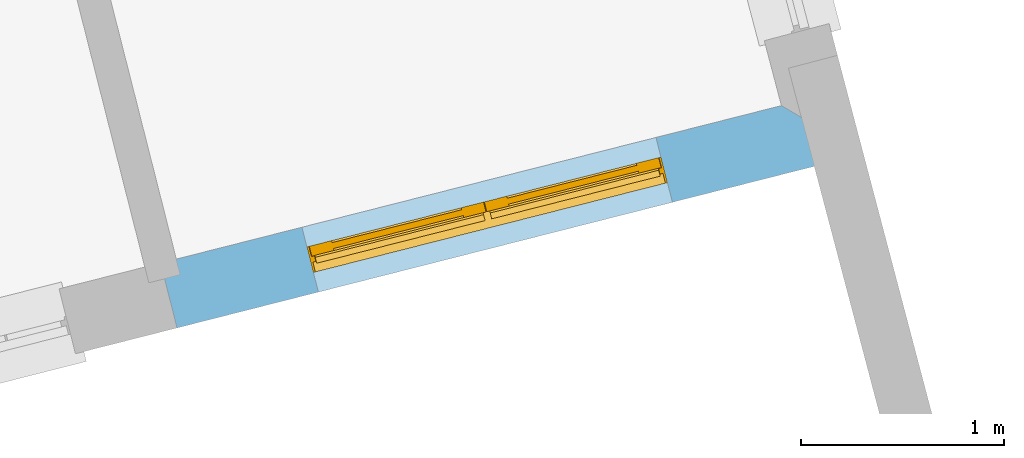
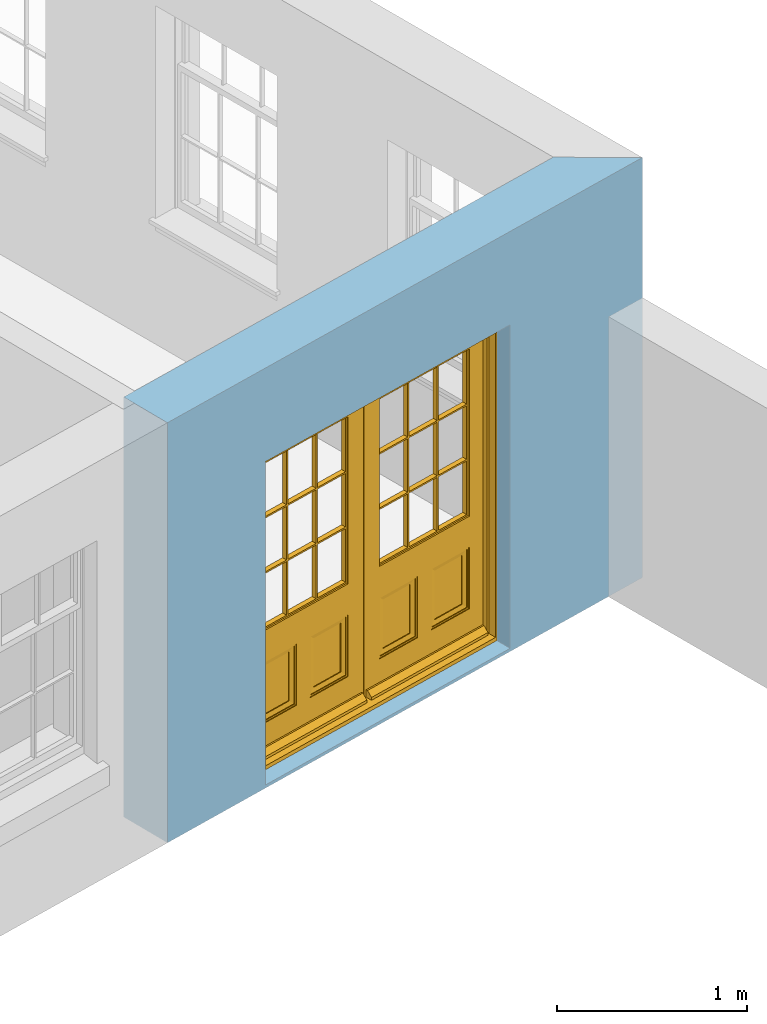
# One storey, part 9 of 15: 1 door, 1 opening, plus 1 element that does not belong to this part.
"""IFC2X3 building model written with IfcOpenShell, lengths in metres."""

from ifc_helpers import new_model, si_unit, frame, origin, place, context, subcontext, project, spatial, polyline, outline, extrude, faceted_brep, material, layer, layer_set, layer_usage, element, fill, save


model = new_model("IFC2X3")

# Units and contexts
model_context = context("Model", 3, world=origin())
body_context = subcontext(model_context, "Body", "Model", "MODEL_VIEW")
ifc_project = project(units=[si_unit("PLANEANGLEUNIT", "RADIAN"), si_unit("MASSUNIT", "GRAM", prefix="KILO"), si_unit("FORCEUNIT", "NEWTON", prefix="KILO"), si_unit("LENGTHUNIT", "METRE")], contexts=[model_context])

# Site, building, storey
site_placement = place(None, origin())
site = spatial("IfcSite", under=ifc_project, at=site_placement, CompositionType="ELEMENT")
building_placement = place(None, origin())
building = spatial("IfcBuilding", under=site, at=building_placement, Name="Building plot-13", CompositionType="ELEMENT")
storey_placement = place(None, frame((0.0, 0.0, 4.0)))
storey = spatial("IfcBuildingStorey", under=building, at=storey_placement, Name="Floor 0", CompositionType="ELEMENT", Elevation=4.0)

# Wall, opening, door
ifc_material = material(Name="Masonry")
ifc_layer = layer(ifc_material, 0.33, ventilated=False)
ifc_layer_set = layer_set([ifc_layer], Name="My Wall")
ifc_layer_usage = layer_usage(ifc_layer_set, "AXIS2", "NEGATIVE", 0.08)
wall_placement = place(storey_placement, origin())
wall = element("IfcWallStandardCase", 1, at=wall_placement, inside=storey, material=ifc_layer_usage, Name="exterior", context=body_context, shape_type="SweptSolid", body=[
    extrude(outline(polyline([(76.9221166060511, 46.4727132498904), (77.0032448604169, 46.1528410780099), (80.3857854678444, 47.0107450750622), (79.9817754258731, 47.2487256724398), (76.9221166060511, 46.4727132498904)])), origin(), (0.0, 0.0, 1.0), 2.7),
])
opening_placement = place(storey_placement, frame((0.0, 0.0, 0.0199999999999996)))
opening = element("IfcOpeningElement", 2, at=opening_placement, cuts=wall, Name="Opening", ObjectType="Opening", context=body_context, shape_type="SweptSolid", body=[
    extrude(outline(polyline([(77.6998328061211, 46.3295146651964), (79.4445901072876, 46.7720324162827), (79.3634618529217, 47.0919045881632), (77.6187045517553, 46.6493868370769), (77.6998328061211, 46.3295146651964)])), origin(), (0.0, 0.0, 1.0), 2.08),
])
door_placement = place(storey_placement, frame((77.6383720073591, 46.5718420681362, 0.0199999999999996), z_axis=(0.0, 0.0, 1.0), x_axis=(1.74475730116643, 0.442517751086271, 0.0)))
door = element("IfcDoor", 3, at=door_placement, inside=storey, Name="living outside door", OverallHeight=2.08, OverallWidth=1.8, context=body_context, shape_type="Brep", held_by="IfcProductRepresentation", body=[
    faceted_brep([(0.545, -0.055, 0.265), (0.745, -0.055, 0.265), (0.745, -0.05, 0.265), (0.545, -0.05, 0.265), (0.745, -0.05, 0.58), (0.545, -0.05, 0.58), (0.545, -0.055, 0.58), (0.515, -0.06, 0.235), (0.775, -0.06, 0.235), (0.745, -0.055, 0.58), (0.515, -0.06, 0.61), (0.515, -0.065, 0.235), (0.775, -0.065, 0.235), (0.775, -0.06, 0.61), (0.515, -0.065, 0.61), (0.785, -0.065, 0.225), (0.505, -0.065, 0.225), (0.775, -0.065, 0.61), (0.505, -0.065, 0.62), (0.785, -0.065, 0.62), (0.505, -0.07, 0.225), (0.785, -0.07, 0.225), (0.505, -0.07, 0.62), (0.785, -0.07, 0.62), (0.883, -0.07, 0.075), (0.898, -0.07, 0.075), (0.405, -0.07, 0.62), (0.405, -0.07, 0.225), (0.027, -0.07, 0.075), (0.785, -0.07, 0.82), (0.125, -0.07, 0.82), (0.405, -0.065, 0.62), (0.405, -0.065, 0.225), (0.898, -0.07, 2.068), (0.027, -0.08, 0.075), (0.883, -0.08, 0.075), (0.125, -0.07, 0.225), (0.012, -0.07, 0.075), (0.785, -0.06, 0.82), (0.125, -0.06, 0.82), (0.125, -0.07, 0.62), (0.125, -0.065, 0.62), (0.395, -0.065, 0.61), (0.395, -0.065, 0.235), (0.125, -0.065, 0.225), (0.785, -0.07, 1.895), (0.027, -0.11, 0.045), (0.883, -0.11, 0.045), (0.558333, -0.06, 0.83), (0.351667, -0.06, 0.83), (0.125, -0.07, 1.895), (0.125, -0.06, 1.895), (0.785, -0.06, 1.895), (0.012, -0.07, 2.068), (0.135, -0.065, 0.61), (0.395, -0.06, 0.61), (0.395, -0.06, 0.235), (0.135, -0.065, 0.235), (0.027, -0.11, 0.027), (0.883, -0.11, 0.027), (0.568333, -0.06, 0.83), (0.558333, -0.03, 0.83), (0.351667, -0.03, 0.83), (0.341667, -0.06, 0.83), (0.135, -0.06, 1.185), (0.135, -0.06, 1.53), (0.775, -0.06, 1.53), (0.775, -0.06, 1.185), (0.135, -0.06, 0.61), (0.365, -0.055, 0.58), (0.365, -0.055, 0.265), (0.135, -0.06, 0.235), (0.568333, -0.06, 1.175), (0.558333, -0.06, 1.175), (0.775, -0.06, 0.83), (0.558333, -0.03, 1.175), (0.785, -0.03, 0.82), (0.125, -0.03, 0.82), (0.351667, -0.03, 1.175), (0.351667, -0.06, 1.175), (0.341667, -0.06, 1.175), (0.135, -0.06, 0.83), (0.135, -0.06, 1.175), (0.135, -0.03, 1.185), (0.135, -0.03, 1.53), (0.135, -0.06, 1.54), (0.351667, -0.06, 1.885), (0.558333, -0.06, 1.885), (0.775, -0.03, 1.53), (0.775, -0.03, 1.185), (0.775, -0.06, 1.175), (0.775, -0.06, 1.54), (0.165, -0.055, 0.58), (0.365, -0.05, 0.58), (0.365, -0.05, 0.265), (0.165, -0.055, 0.265), (0.568333, -0.03, 0.83), (0.568333, -0.03, 1.175), (0.568333, -0.06, 1.185), (0.558333, -0.06, 1.185), (0.775, -0.03, 0.83), (0.785, -0.02, 0.82), (0.125, -0.02, 0.82), (0.341667, -0.03, 0.83), (0.341667, -0.03, 1.175), (0.351667, -0.06, 1.185), (0.341667, -0.06, 1.185), (0.135, -0.03, 0.83), (0.341667, -0.03, 1.185), (0.125, -0.03, 1.895), (0.341667, -0.03, 1.53), (0.341667, -0.06, 1.53), (0.135, -0.06, 1.885), (0.341667, -0.06, 1.54), (0.341667, -0.06, 1.885), (0.558333, -0.03, 1.885), (0.351667, -0.03, 1.885), (0.568333, -0.06, 1.885), (0.785, -0.03, 1.895), (0.568333, -0.03, 1.185), (0.568333, -0.06, 1.53), (0.568333, -0.03, 1.53), (0.568333, -0.06, 1.54), (0.775, -0.06, 1.885), (0.165, -0.05, 0.58), (0.165, -0.05, 0.265), (0.775, -0.03, 1.175), (0.558333, -0.06, 1.53), (0.351667, -0.03, 1.185), (0.558333, -0.03, 1.185), (0.505, -0.02, 0.62), (0.405, -0.02, 0.62), (0.125, -0.02, 1.895), (0.785, -0.02, 1.895), (0.351667, -0.06, 1.53), (0.135, -0.03, 1.175), (0.135, -0.03, 1.54), (0.341667, -0.03, 1.54), (0.135, -0.03, 1.885), (0.351667, -0.06, 1.54), (0.558333, -0.03, 1.54), (0.558333, -0.06, 1.54), (0.351667, -0.03, 1.54), (0.775, -0.03, 1.54), (0.568333, -0.03, 1.54), (0.775, -0.03, 1.885), (0.558333, -0.03, 1.53), (0.405, -0.02, 0.225), (0.505, -0.02, 0.225), (0.125, -0.02, 0.62), (0.785, -0.02, 0.62), (0.012, -0.02, 2.068), (0.898, -0.02, 2.068), (0.351667, -0.03, 1.53), (0.341667, -0.03, 1.885), (0.568333, -0.03, 1.885), (0.405, -0.025, 0.225), (0.405, -0.025, 0.62), (0.505, -0.025, 0.62), (0.505, -0.025, 0.225), (0.898, -0.02, 0.027), (0.012, -0.02, 0.027), (0.125, -0.025, 0.62), (0.785, -0.025, 0.62), (0.395, -0.025, 0.235), (0.395, -0.025, 0.61), (0.125, -0.02, 0.225), (0.125, -0.025, 0.225), (0.515, -0.025, 0.61), (0.515, -0.025, 0.235), (0.785, -0.02, 0.225), (0.785, -0.025, 0.225), (0.135, -0.025, 0.61), (0.775, -0.025, 0.61), (0.135, -0.025, 0.235), (0.395, -0.03, 0.235), (0.395, -0.03, 0.61), (0.515, -0.03, 0.61), (0.515, -0.03, 0.235), (0.775, -0.025, 0.235), (0.135, -0.03, 0.61), (0.775, -0.03, 0.61), (0.135, -0.03, 0.235), (0.365, -0.035, 0.265), (0.365, -0.035, 0.58), (0.545, -0.035, 0.58), (0.545, -0.035, 0.265), (0.775, -0.03, 0.235), (0.165, -0.035, 0.58), (0.745, -0.035, 0.58), (0.165, -0.035, 0.265), (0.365, -0.04, 0.58), (0.365, -0.04, 0.265), (0.545, -0.04, 0.58), (0.545, -0.04, 0.265), (0.745, -0.035, 0.265), (0.165, -0.04, 0.58), (0.745, -0.04, 0.58), (0.165, -0.04, 0.265), (0.745, -0.04, 0.265), (1.775, -0.072, 0.025), (0.025, -0.072, 0.025), (0.025, -0.1, 0.025), (1.775, -0.1, 0.025), (1.79, -0.02, 0.025), (0.01, -0.02, 0.025), (1.79, -0.072, 0.025), (1.8, -0.02, 0.0), (0.0, -0.02, 0.0), (0.01, -0.072, 0.025), (1.79, -0.072, 2.07), (1.79, -0.02, 2.07), (1.775, -0.072, 2.055), (1.8, -0.02, 2.08), (0.01, -0.02, 2.07), (0.0, -0.02, 2.08), (0.01, -0.072, 2.07), (0.025, -0.072, 2.055), (0.0, -0.15, 2.08), (1.8, -0.15, 2.08), (0.01, -0.15, 2.07), (1.79, -0.15, 2.07), (0.01, -0.1, 2.07), (1.79, -0.1, 2.07), (0.0, -0.15, 0.0), (1.8, -0.15, 0.0), (0.01, -0.15, 0.025), (1.79, -0.15, 0.025), (0.01, -0.1, 0.025), (0.025, -0.1, 2.055), (1.79, -0.1, 0.025), (1.775, -0.1, 2.055), (0.898, -0.07, 0.027), (0.012, -0.07, 0.027), (0.883, -0.07, 0.027), (0.027, -0.07, 0.027), (1.435, -0.055, 0.265), (1.635, -0.055, 0.265), (1.635, -0.05, 0.265), (1.435, -0.05, 0.265), (1.635, -0.05, 0.58), (1.435, -0.05, 0.58), (1.435, -0.055, 0.58), (1.405, -0.06, 0.235), (1.665, -0.06, 0.235), (1.635, -0.055, 0.58), (1.405, -0.06, 0.61), (1.405, -0.065, 0.235), (1.665, -0.065, 0.235), (1.665, -0.06, 0.61), (1.405, -0.065, 0.61), (1.675, -0.065, 0.225), (1.395, -0.065, 0.225), (1.665, -0.065, 0.61), (1.395, -0.065, 0.62), (1.675, -0.065, 0.62), (1.395, -0.07, 0.225), (1.675, -0.07, 0.225), (1.395, -0.07, 0.62), (1.675, -0.07, 0.62), (1.773, -0.07, 0.075), (1.788, -0.07, 0.075), (1.295, -0.07, 0.62), (1.295, -0.07, 0.225), (0.917, -0.07, 0.075), (1.675, -0.07, 0.82), (1.015, -0.07, 0.82), (1.295, -0.065, 0.62), (1.295, -0.065, 0.225), (1.788, -0.07, 2.068), (0.917, -0.08, 0.075), (1.773, -0.08, 0.075), (1.015, -0.07, 0.225), (0.902, -0.07, 0.075), (1.675, -0.06, 0.82), (1.015, -0.06, 0.82), (1.015, -0.07, 0.62), (1.015, -0.065, 0.62), (1.285, -0.065, 0.61), (1.285, -0.065, 0.235), (1.015, -0.065, 0.225), (1.675, -0.07, 1.895), (0.917, -0.11, 0.045), (1.773, -0.11, 0.045), (1.448333, -0.06, 0.83), (1.241667, -0.06, 0.83), (1.015, -0.07, 1.895), (1.015, -0.06, 1.895), (1.675, -0.06, 1.895), (0.902, -0.07, 2.068), (1.025, -0.065, 0.61), (1.285, -0.06, 0.61), (1.285, -0.06, 0.235), (1.025, -0.065, 0.235), (0.917, -0.11, 0.027), (1.773, -0.11, 0.027), (1.458333, -0.06, 0.83), (1.448333, -0.03, 0.83), (1.241667, -0.03, 0.83), (1.231667, -0.06, 0.83), (1.025, -0.06, 1.185), (1.025, -0.06, 1.53), (1.665, -0.06, 1.53), (1.665, -0.06, 1.185), (1.025, -0.06, 0.61), (1.255, -0.055, 0.58), (1.255, -0.055, 0.265), (1.025, -0.06, 0.235), (1.458333, -0.06, 1.175), (1.448333, -0.06, 1.175), (1.665, -0.06, 0.83), (1.448333, -0.03, 1.175), (1.675, -0.03, 0.82), (1.015, -0.03, 0.82), (1.241667, -0.03, 1.175), (1.241667, -0.06, 1.175), (1.231667, -0.06, 1.175), (1.025, -0.06, 0.83), (1.025, -0.06, 1.175), (1.025, -0.03, 1.185), (1.025, -0.03, 1.53), (1.025, -0.06, 1.54), (1.241667, -0.06, 1.885), (1.448333, -0.06, 1.885), (1.665, -0.03, 1.53), (1.665, -0.03, 1.185), (1.665, -0.06, 1.175), (1.665, -0.06, 1.54), (1.055, -0.055, 0.58), (1.255, -0.05, 0.58), (1.255, -0.05, 0.265), (1.055, -0.055, 0.265), (1.458333, -0.03, 0.83), (1.458333, -0.03, 1.175), (1.458333, -0.06, 1.185), (1.448333, -0.06, 1.185), (1.665, -0.03, 0.83), (1.675, -0.02, 0.82), (1.015, -0.02, 0.82), (1.231667, -0.03, 0.83), (1.231667, -0.03, 1.175), (1.241667, -0.06, 1.185), (1.231667, -0.06, 1.185), (1.025, -0.03, 0.83), (1.231667, -0.03, 1.185), (1.015, -0.03, 1.895), (1.231667, -0.03, 1.53), (1.231667, -0.06, 1.53), (1.025, -0.06, 1.885), (1.231667, -0.06, 1.54), (1.231667, -0.06, 1.885), (1.448333, -0.03, 1.885), (1.241667, -0.03, 1.885), (1.458333, -0.06, 1.885), (1.675, -0.03, 1.895), (1.458333, -0.03, 1.185), (1.458333, -0.06, 1.53), (1.458333, -0.03, 1.53), (1.458333, -0.06, 1.54), (1.665, -0.06, 1.885), (1.055, -0.05, 0.58), (1.055, -0.05, 0.265), (1.665, -0.03, 1.175), (1.448333, -0.06, 1.53), (1.241667, -0.03, 1.185), (1.448333, -0.03, 1.185), (1.395, -0.02, 0.62), (1.295, -0.02, 0.62), (1.015, -0.02, 1.895), (1.675, -0.02, 1.895), (1.241667, -0.06, 1.53), (1.025, -0.03, 1.175), (1.025, -0.03, 1.54), (1.231667, -0.03, 1.54), (1.025, -0.03, 1.885), (1.241667, -0.06, 1.54), (1.448333, -0.03, 1.54), (1.448333, -0.06, 1.54), (1.241667, -0.03, 1.54), (1.665, -0.03, 1.54), (1.458333, -0.03, 1.54), (1.665, -0.03, 1.885), (1.448333, -0.03, 1.53), (1.295, -0.02, 0.225), (1.395, -0.02, 0.225), (1.015, -0.02, 0.62), (1.675, -0.02, 0.62), (0.902, -0.02, 2.068), (1.788, -0.02, 2.068), (1.241667, -0.03, 1.53), (1.231667, -0.03, 1.885), (1.458333, -0.03, 1.885), (1.295, -0.025, 0.225), (1.295, -0.025, 0.62), (1.395, -0.025, 0.62), (1.395, -0.025, 0.225), (1.788, -0.02, 0.027), (0.902, -0.02, 0.027), (1.015, -0.025, 0.62), (1.675, -0.025, 0.62), (1.285, -0.025, 0.235), (1.285, -0.025, 0.61), (1.015, -0.02, 0.225), (1.015, -0.025, 0.225), (1.405, -0.025, 0.61), (1.405, -0.025, 0.235), (1.675, -0.02, 0.225), (1.675, -0.025, 0.225), (1.025, -0.025, 0.61), (1.665, -0.025, 0.61), (1.025, -0.025, 0.235), (1.285, -0.03, 0.235), (1.285, -0.03, 0.61), (1.405, -0.03, 0.61), (1.405, -0.03, 0.235), (1.665, -0.025, 0.235), (1.025, -0.03, 0.61), (1.665, -0.03, 0.61), (1.025, -0.03, 0.235), (1.255, -0.035, 0.265), (1.255, -0.035, 0.58), (1.435, -0.035, 0.58), (1.435, -0.035, 0.265), (1.665, -0.03, 0.235), (1.055, -0.035, 0.58), (1.635, -0.035, 0.58), (1.055, -0.035, 0.265), (1.255, -0.04, 0.58), (1.255, -0.04, 0.265), (1.435, -0.04, 0.58), (1.435, -0.04, 0.265), (1.635, -0.035, 0.265), (1.055, -0.04, 0.58), (1.635, -0.04, 0.58), (1.055, -0.04, 0.265), (1.635, -0.04, 0.265), (1.788, -0.07, 0.027), (0.902, -0.07, 0.027), (1.773, -0.07, 0.027), (0.917, -0.07, 0.027)], [[[0, 1, 2, 3]], [[2, 4, 5, 3]], [[0, 3, 5, 6]], [[1, 0, 7, 8]], [[9, 4, 2, 1]], [[9, 6, 5, 4]], [[0, 6, 10, 7]], [[8, 7, 11, 12]], [[8, 13, 9, 1]], [[13, 10, 6, 9]], [[7, 10, 14, 11]], [[15, 12, 11, 16]], [[12, 17, 13, 8]], [[17, 14, 10, 13]], [[18, 16, 11, 14]], [[15, 19, 17, 12]], [[15, 16, 20, 21]], [[14, 17, 19, 18]], [[16, 18, 22, 20]], [[21, 23, 19, 15]], [[24, 25, 21, 20]], [[23, 22, 18, 19]], [[20, 22, 26, 27]], [[23, 21, 25]], [[28, 24, 20, 27]], [[22, 23, 29]], [[29, 30, 26, 22]], [[27, 26, 31, 32]], [[23, 25, 33, 29]], [[34, 35, 24, 28]], [[28, 27, 36, 37]], [[38, 39, 30, 29]], [[26, 30, 40]], [[26, 40, 41, 31]], [[42, 43, 32, 31]], [[32, 44, 36, 27]], [[33, 45, 29]], [[46, 47, 35, 34]], [[36, 40, 37]], [[39, 38, 48, 49]], [[50, 30, 39, 51]], [[29, 45, 52, 38]], [[53, 37, 40, 30]], [[44, 41, 40, 36]], [[31, 41, 54, 42]], [[43, 42, 55, 56]], [[57, 44, 32, 43]], [[50, 45, 33, 53]], [[47, 46, 58, 59]], [[60, 48, 38]], [[49, 48, 61, 62]], [[49, 63, 39]], [[50, 53, 30]], [[51, 39, 64, 65]], [[45, 50, 51, 52]], [[66, 67, 38, 52]], [[57, 54, 41, 44]], [[42, 54, 68, 55]], [[56, 55, 69, 70]], [[56, 71, 57, 43]], [[60, 72, 73, 48]], [[60, 38, 74]], [[48, 73, 75, 61]], [[76, 77, 62, 61]], [[62, 78, 79, 49]], [[49, 79, 80, 63]], [[63, 81, 39]], [[82, 64, 39]], [[65, 64, 83, 84]], [[85, 51, 65]], [[52, 51, 86, 87]], [[88, 89, 67, 66]], [[90, 38, 67]], [[91, 66, 52]], [[71, 68, 54, 57]], [[55, 68, 92, 69]], [[69, 93, 94, 70]], [[70, 95, 71, 56]], [[96, 97, 72, 60]], [[73, 72, 98, 99]], [[74, 38, 90]], [[100, 96, 60, 74]], [[75, 73, 79, 78]], [[61, 75, 97, 96]], [[101, 102, 77, 76]], [[77, 103, 62]], [[96, 76, 61]], [[103, 104, 78, 62]], [[80, 79, 105, 106]], [[63, 80, 104, 103]], [[81, 63, 103, 107]], [[81, 82, 39]], [[106, 64, 82, 80]], [[106, 108, 83, 64]], [[84, 83, 77, 109]], [[110, 111, 65, 84]], [[112, 51, 85]], [[113, 85, 65, 111]], [[114, 86, 51]], [[115, 87, 86, 116]], [[117, 52, 87]], [[118, 76, 89, 88]], [[119, 98, 67, 89]], [[120, 121, 88, 66]], [[67, 98, 72, 90]], [[91, 122, 120, 66]], [[91, 52, 123]], [[95, 92, 68, 71]], [[69, 92, 124, 93]], [[94, 93, 124, 125]], [[94, 125, 95, 70]], [[72, 97, 126, 90]], [[127, 99, 98, 120]], [[99, 105, 79, 73]], [[74, 90, 126, 100]], [[96, 100, 76]], [[128, 129, 75, 78]], [[97, 75, 129, 119]], [[130, 131, 102, 101]], [[109, 77, 102, 132]], [[133, 101, 76, 118]], [[77, 107, 103]], [[78, 104, 108, 128]], [[111, 106, 105, 134]], [[104, 80, 82, 135]], [[107, 135, 82, 81]], [[110, 108, 106, 111]], [[104, 135, 83, 108]], [[83, 135, 77]], [[136, 84, 109]], [[110, 84, 136, 137]], [[114, 51, 112]], [[85, 136, 138, 112]], [[113, 137, 136, 85]], [[111, 134, 139, 113]], [[86, 114, 113, 139]], [[140, 141, 87, 115]], [[139, 142, 116, 86]], [[109, 118, 115, 116]], [[117, 123, 52]], [[117, 87, 141, 122]], [[126, 89, 76]], [[143, 118, 88]], [[120, 98, 119, 121]], [[119, 89, 126, 97]], [[144, 143, 88, 121]], [[144, 122, 91, 143]], [[127, 120, 122, 141]], [[143, 91, 123, 145]], [[124, 92, 95, 125]], [[146, 129, 99, 127]], [[99, 129, 128, 105]], [[100, 126, 76]], [[121, 119, 129, 146]], [[147, 131, 130, 148]], [[131, 149, 102]], [[130, 101, 150]], [[102, 151, 132]], [[118, 109, 132, 133]], [[101, 133, 152]], [[107, 77, 135]], [[153, 128, 108, 110]], [[134, 105, 128, 153]], [[109, 138, 136]], [[153, 110, 137, 142]], [[154, 114, 112, 138]], [[137, 113, 114, 154]], [[141, 139, 134, 127]], [[141, 140, 142, 139]], [[144, 140, 115, 155]], [[142, 137, 154, 116]], [[155, 115, 118]], [[116, 154, 109]], [[117, 155, 145, 123]], [[122, 144, 155, 117]], [[143, 145, 118]], [[121, 146, 140, 144]], [[146, 127, 134, 153]], [[156, 157, 131, 147]], [[148, 130, 158, 159]], [[148, 160, 161, 147]], [[157, 162, 149, 131]], [[161, 151, 102, 149]], [[101, 152, 160, 150]], [[163, 158, 130, 150]], [[151, 152, 133, 132]], [[154, 138, 109]], [[142, 140, 146, 153]], [[145, 155, 118]], [[157, 156, 164, 165]], [[147, 166, 167, 156]], [[168, 169, 159, 158]], [[170, 148, 159, 171]], [[148, 170, 160]], [[166, 147, 161]], [[172, 162, 157, 165]], [[166, 149, 162, 167]], [[166, 161, 149]], [[150, 160, 170]], [[163, 173, 168, 158]], [[171, 163, 150, 170]], [[174, 164, 156, 167]], [[175, 176, 165, 164]], [[169, 168, 177, 178]], [[171, 159, 169, 179]], [[167, 162, 172, 174]], [[176, 180, 172, 165]], [[179, 173, 163, 171]], [[181, 177, 168, 173]], [[164, 174, 182, 175]], [[183, 184, 176, 175]], [[178, 177, 185, 186]], [[179, 169, 178, 187]], [[174, 172, 180, 182]], [[184, 188, 180, 176]], [[187, 181, 173, 179]], [[189, 185, 177, 181]], [[175, 182, 190, 183]], [[191, 184, 183, 192]], [[185, 193, 194, 186]], [[187, 178, 186, 195]], [[182, 180, 188, 190]], [[191, 196, 188, 184]], [[195, 189, 181, 187]], [[197, 193, 185, 189]], [[183, 190, 198, 192]], [[198, 196, 191, 192]], [[194, 193, 197, 199]], [[195, 186, 194, 199]], [[188, 196, 198, 190]], [[197, 189, 195, 199]], [[200, 201, 202, 203]], [[201, 200, 204, 205]], [[206, 204, 200]], [[204, 207, 208, 205]], [[209, 201, 205]], [[210, 211, 204, 206]], [[206, 200, 212, 210]], [[211, 213, 207, 204]], [[214, 205, 208, 215]], [[216, 217, 201, 209]], [[205, 214, 216, 209]], [[216, 214, 211, 210]], [[210, 212, 217, 216]], [[214, 215, 213, 211]], [[218, 219, 213, 215]], [[219, 218, 220, 221]], [[221, 220, 222, 223]], [[215, 208, 224, 218]], [[225, 224, 208, 207]], [[224, 226, 220, 218]], [[224, 225, 227, 226]], [[219, 225, 207, 213]], [[228, 222, 220, 226]], [[219, 221, 227, 225]], [[226, 227, 203, 202]], [[202, 229, 222, 228]], [[228, 226, 202]], [[227, 221, 223, 230]], [[230, 203, 227]], [[217, 229, 202, 201]], [[231, 223, 222, 229]], [[230, 223, 231, 203]], [[231, 229, 217, 212]], [[212, 200, 203, 231]], [[33, 152, 151, 53]], [[25, 160, 152, 33]], [[161, 37, 53, 151]], [[232, 160, 25]], [[161, 233, 37]], [[160, 232, 234]], [[24, 234, 232, 25]], [[233, 161, 235]], [[37, 233, 235, 28]], [[161, 160, 234, 235]], [[35, 47, 234, 24]], [[28, 235, 46, 34]], [[58, 235, 234, 59]], [[59, 234, 47]], [[58, 46, 235]], [[236, 237, 238, 239]], [[238, 240, 241, 239]], [[236, 239, 241, 242]], [[237, 236, 243, 244]], [[245, 240, 238, 237]], [[245, 242, 241, 240]], [[236, 242, 246, 243]], [[244, 243, 247, 248]], [[244, 249, 245, 237]], [[249, 246, 242, 245]], [[243, 246, 250, 247]], [[251, 248, 247, 252]], [[248, 253, 249, 244]], [[253, 250, 246, 249]], [[254, 252, 247, 250]], [[251, 255, 253, 248]], [[251, 252, 256, 257]], [[250, 253, 255, 254]], [[252, 254, 258, 256]], [[257, 259, 255, 251]], [[260, 261, 257, 256]], [[259, 258, 254, 255]], [[256, 258, 262, 263]], [[259, 257, 261]], [[264, 260, 256, 263]], [[258, 259, 265]], [[265, 266, 262, 258]], [[263, 262, 267, 268]], [[259, 261, 269, 265]], [[270, 271, 260, 264]], [[264, 263, 272, 273]], [[274, 275, 266, 265]], [[262, 266, 276]], [[262, 276, 277, 267]], [[278, 279, 268, 267]], [[268, 280, 272, 263]], [[269, 281, 265]], [[282, 283, 271, 270]], [[272, 276, 273]], [[275, 274, 284, 285]], [[286, 266, 275, 287]], [[265, 281, 288, 274]], [[289, 273, 276, 266]], [[280, 277, 276, 272]], [[267, 277, 290, 278]], [[279, 278, 291, 292]], [[293, 280, 268, 279]], [[286, 281, 269, 289]], [[283, 282, 294, 295]], [[296, 284, 274]], [[285, 284, 297, 298]], [[285, 299, 275]], [[286, 289, 266]], [[287, 275, 300, 301]], [[281, 286, 287, 288]], [[302, 303, 274, 288]], [[293, 290, 277, 280]], [[278, 290, 304, 291]], [[292, 291, 305, 306]], [[292, 307, 293, 279]], [[296, 308, 309, 284]], [[296, 274, 310]], [[284, 309, 311, 297]], [[312, 313, 298, 297]], [[298, 314, 315, 285]], [[285, 315, 316, 299]], [[299, 317, 275]], [[318, 300, 275]], [[301, 300, 319, 320]], [[321, 287, 301]], [[288, 287, 322, 323]], [[324, 325, 303, 302]], [[326, 274, 303]], [[327, 302, 288]], [[307, 304, 290, 293]], [[291, 304, 328, 305]], [[305, 329, 330, 306]], [[306, 331, 307, 292]], [[332, 333, 308, 296]], [[309, 308, 334, 335]], [[310, 274, 326]], [[336, 332, 296, 310]], [[311, 309, 315, 314]], [[297, 311, 333, 332]], [[337, 338, 313, 312]], [[313, 339, 298]], [[332, 312, 297]], [[339, 340, 314, 298]], [[316, 315, 341, 342]], [[299, 316, 340, 339]], [[317, 299, 339, 343]], [[317, 318, 275]], [[342, 300, 318, 316]], [[342, 344, 319, 300]], [[320, 319, 313, 345]], [[346, 347, 301, 320]], [[348, 287, 321]], [[349, 321, 301, 347]], [[350, 322, 287]], [[351, 323, 322, 352]], [[353, 288, 323]], [[354, 312, 325, 324]], [[355, 334, 303, 325]], [[356, 357, 324, 302]], [[303, 334, 308, 326]], [[327, 358, 356, 302]], [[327, 288, 359]], [[331, 328, 304, 307]], [[305, 328, 360, 329]], [[330, 329, 360, 361]], [[330, 361, 331, 306]], [[308, 333, 362, 326]], [[363, 335, 334, 356]], [[335, 341, 315, 309]], [[310, 326, 362, 336]], [[332, 336, 312]], [[364, 365, 311, 314]], [[333, 311, 365, 355]], [[366, 367, 338, 337]], [[345, 313, 338, 368]], [[369, 337, 312, 354]], [[313, 343, 339]], [[314, 340, 344, 364]], [[347, 342, 341, 370]], [[340, 316, 318, 371]], [[343, 371, 318, 317]], [[346, 344, 342, 347]], [[340, 371, 319, 344]], [[319, 371, 313]], [[372, 320, 345]], [[346, 320, 372, 373]], [[350, 287, 348]], [[321, 372, 374, 348]], [[349, 373, 372, 321]], [[347, 370, 375, 349]], [[322, 350, 349, 375]], [[376, 377, 323, 351]], [[375, 378, 352, 322]], [[345, 354, 351, 352]], [[353, 359, 288]], [[353, 323, 377, 358]], [[362, 325, 312]], [[379, 354, 324]], [[356, 334, 355, 357]], [[355, 325, 362, 333]], [[380, 379, 324, 357]], [[380, 358, 327, 379]], [[363, 356, 358, 377]], [[379, 327, 359, 381]], [[360, 328, 331, 361]], [[382, 365, 335, 363]], [[335, 365, 364, 341]], [[336, 362, 312]], [[357, 355, 365, 382]], [[383, 367, 366, 384]], [[367, 385, 338]], [[366, 337, 386]], [[338, 387, 368]], [[354, 345, 368, 369]], [[337, 369, 388]], [[343, 313, 371]], [[389, 364, 344, 346]], [[370, 341, 364, 389]], [[345, 374, 372]], [[389, 346, 373, 378]], [[390, 350, 348, 374]], [[373, 349, 350, 390]], [[377, 375, 370, 363]], [[377, 376, 378, 375]], [[380, 376, 351, 391]], [[378, 373, 390, 352]], [[391, 351, 354]], [[352, 390, 345]], [[353, 391, 381, 359]], [[358, 380, 391, 353]], [[379, 381, 354]], [[357, 382, 376, 380]], [[382, 363, 370, 389]], [[392, 393, 367, 383]], [[384, 366, 394, 395]], [[384, 396, 397, 383]], [[393, 398, 385, 367]], [[397, 387, 338, 385]], [[337, 388, 396, 386]], [[399, 394, 366, 386]], [[387, 388, 369, 368]], [[390, 374, 345]], [[378, 376, 382, 389]], [[381, 391, 354]], [[393, 392, 400, 401]], [[383, 402, 403, 392]], [[404, 405, 395, 394]], [[406, 384, 395, 407]], [[384, 406, 396]], [[402, 383, 397]], [[408, 398, 393, 401]], [[402, 385, 398, 403]], [[402, 397, 385]], [[386, 396, 406]], [[399, 409, 404, 394]], [[407, 399, 386, 406]], [[410, 400, 392, 403]], [[411, 412, 401, 400]], [[405, 404, 413, 414]], [[407, 395, 405, 415]], [[403, 398, 408, 410]], [[412, 416, 408, 401]], [[415, 409, 399, 407]], [[417, 413, 404, 409]], [[400, 410, 418, 411]], [[419, 420, 412, 411]], [[414, 413, 421, 422]], [[415, 405, 414, 423]], [[410, 408, 416, 418]], [[420, 424, 416, 412]], [[423, 417, 409, 415]], [[425, 421, 413, 417]], [[411, 418, 426, 419]], [[427, 420, 419, 428]], [[421, 429, 430, 422]], [[423, 414, 422, 431]], [[418, 416, 424, 426]], [[427, 432, 424, 420]], [[431, 425, 417, 423]], [[433, 429, 421, 425]], [[419, 426, 434, 428]], [[434, 432, 427, 428]], [[430, 429, 433, 435]], [[431, 422, 430, 435]], [[424, 432, 434, 426]], [[433, 425, 431, 435]], [[269, 388, 387, 289]], [[261, 396, 388, 269]], [[397, 273, 289, 387]], [[436, 396, 261]], [[397, 437, 273]], [[396, 436, 438]], [[260, 438, 436, 261]], [[437, 397, 439]], [[273, 437, 439, 264]], [[397, 396, 438, 439]], [[271, 283, 438, 260]], [[264, 439, 282, 270]], [[294, 439, 438, 295]], [[295, 438, 283]], [[294, 282, 439]]]),
])
fill(opening, door)

save(model, "model.ifc")
